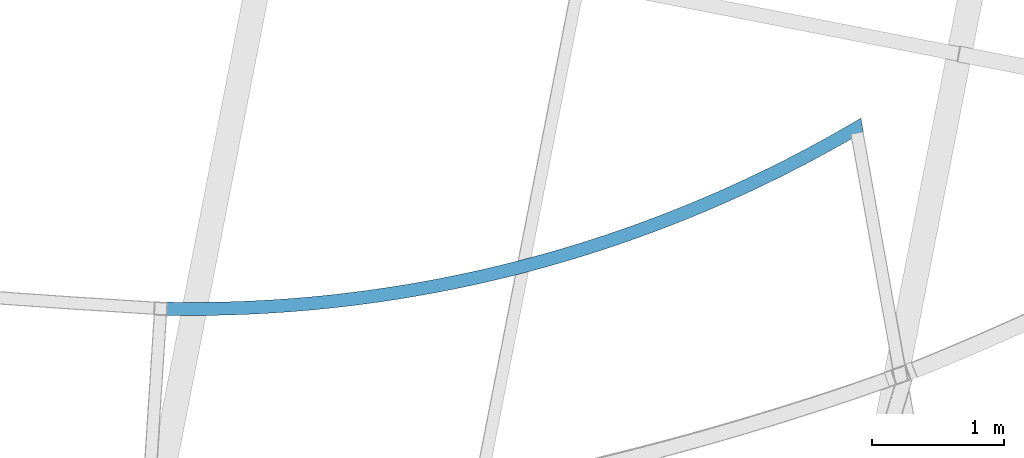
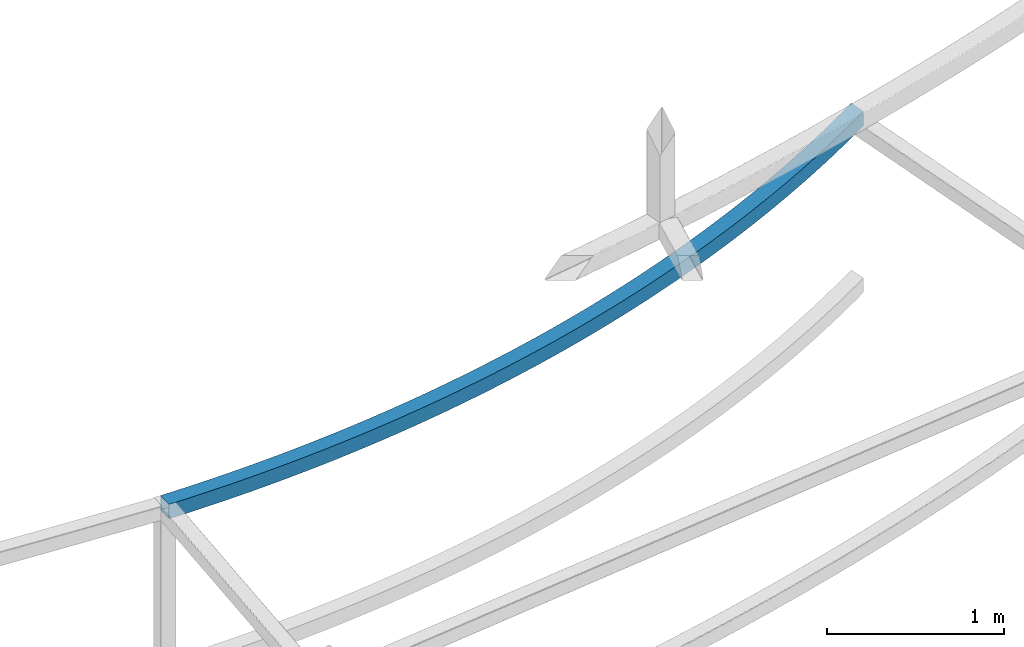
# One storey, part 210 of 215: 1 beam, 1 element without a shape of its own.
"""IFC2X3 building model written with IfcOpenShell, lengths in millimetres."""

from ifc_helpers import new_model, si_unit, frame, origin_with_axes, place, context, subcontext, project, spatial, faceted_brep, material, type_object, element, aggregate, save


model = new_model("IFC2X3")

# Units and contexts
model_context = context("Model", 3, precision=1e-05, world=origin_with_axes())
body_context = subcontext(model_context, "Body", "Model", "MODEL_VIEW")
ifc_project = project(units=[si_unit("LENGTHUNIT", "METRE", prefix="MILLI"), si_unit("AREAUNIT", "SQUARE_METRE"), si_unit("VOLUMEUNIT", "CUBIC_METRE"), si_unit("MASSUNIT", "GRAM", prefix="KILO"), si_unit("TIMEUNIT", "SECOND"), si_unit("PLANEANGLEUNIT", "RADIAN"), si_unit("SOLIDANGLEUNIT", "STERADIAN"), si_unit("THERMODYNAMICTEMPERATUREUNIT", "DEGREE_CELSIUS"), si_unit("LUMINOUSINTENSITYUNIT", "LUMEN")], contexts=[model_context])

# Site, building, storey
site_placement = place(None, origin_with_axes())
site = spatial("IfcSite", under=ifc_project, at=site_placement, CompositionType="ELEMENT")
building_placement = place(site_placement, origin_with_axes())
building = spatial("IfcBuilding", under=site, at=building_placement, Name="Undefined", CompositionType="ELEMENT")
storey_placement = place(building_placement, origin_with_axes())
storey = spatial("IfcBuildingStorey", under=building, at=storey_placement, Name="Undefined", CompositionType="ELEMENT", Elevation=0.0)

# Assembly, beam
assembly_placement = place(storey_placement, origin_with_axes())
assembly = element("IfcElementAssembly", 1, at=assembly_placement, inside=storey, Name="Steel Assembly", AssemblyPlace="NOTDEFINED", PredefinedType="RIGID_FRAME")
ifc_material = material(Name="STEEL/S275JR")
beam_type = type_object("IfcBeamType", PredefinedType="NOTDEFINED")
beam_placement = place(assembly_placement, frame((79292.5596210505, 5933.80750631125, 6760.00000147687), z_axis=(-0.254036429912331, 0.967194650666244, 0.0), x_axis=(0.967194650666242, 0.254036429912337, 0.0)))
beam = element("IfcBeam", 2, at=beam_placement, type_object=beam_type, material=ifc_material, Name="POUTRE", context=body_context, shape_type="Brep", body=[
    faceted_brep([(13.8027650535223, 50.0, 48.0570876861802), (13.8027650535223, -50.0, 48.0570876861802), (120.962516663611, -50.0, 17.926930383619), (120.962516663611, 50.0, 17.926930383619), (228.452636376329, -50.0, -11.0025166964588), (228.452636376329, 50.0, -11.0025166964588), (336.259670852232, -50.0, -38.7276327778127), (336.259670852232, 50.0, -38.7276327778127), (444.370127087197, -50.0, -65.2449478168783), (444.370127087197, 50.0, -65.2449478168783), (552.770474101198, -50.0, -90.5511429370781), (552.770474101198, 50.0, -90.5511429370781), (661.447144631748, -50.0, -114.643050844223), (661.447144631748, 50.0, -114.643050844223), (770.386536832113, -50.0, -137.517656222892), (770.386536832113, 50.0, -137.517656222892), (879.575015973576, -50.0, -159.172096113844), (879.575015973576, 50.0, -159.172096113844), (988.998916151962, -50.0, -179.603660272365), (988.998916151962, 50.0, -179.603660272365), (1098.64454199812, -50.0, -198.809791507432), (1098.64454199812, 50.0, -198.809791507432), (1208.49817039195, -50.0, -216.788086001812), (1208.49817039195, 50.0, -216.788086001812), (1318.54605217997, -50.0, -233.536293612895), (1318.54605217997, 50.0, -233.536293612895), (1428.77441389619, -50.0, -249.052318154325), (1428.77441389619, 50.0, -249.052318154325), (1539.16945948597, -50.0, -263.334217658366), (1539.16945948597, 50.0, -263.334217658366), (1649.71737203271, -50.0, -276.380204618938), (1649.71737203271, 50.0, -276.380204618938), (1760.40431548712, -50.0, -288.188646215367), (1760.40431548712, 50.0, -288.188646215367), (1871.21643639897, -50.0, -298.758064516705), (1871.21643639897, 50.0, -298.758064516705), (1982.13986565101, -50.0, -308.087136666752), (1982.13986565101, 50.0, -308.087136666752), (2093.16072019475, -50.0, -316.174695049598), (2093.16072019475, 50.0, -316.174695049598), (2204.26510478801, -50.0, -323.019727435752), (2204.26510478801, 50.0, -323.019727435752), (2315.43911373413, -50.0, -328.621377108855), (2315.43911373413, 50.0, -328.621377108855), (2426.66883262237, -50.0, -332.978942972903), (2426.66883262237, 50.0, -332.978942972903), (2537.94034006934, -50.0, -336.091879639967), (2537.94034006934, 50.0, -336.091879639967), (2649.23970946147, -50.0, -337.959797498483), (2649.23970946147, 50.0, -337.959797498483), (2760.55301069804, -50.0, -338.582462762013), (2760.55301069804, 50.0, -338.582462762013), (2871.86631193462, -50.0, -337.959797498483), (2871.86631193462, 50.0, -337.959797498483), (2983.16568132676, -50.0, -336.091879639966), (2983.16568132676, 50.0, -336.091879639966), (3094.43718877374, -50.0, -332.978942972903), (3094.43718877374, 50.0, -332.978942972903), (3205.66690766196, -50.0, -328.621377108859), (3205.66690766196, 50.0, -328.621377108859), (3316.8409166081, -50.0, -323.019727435752), (3316.8409166081, 50.0, -323.019727435752), (3427.94530120135, -50.0, -316.174695049598), (3427.94530120135, 50.0, -316.174695049598), (3538.96615574509, -50.0, -308.087136666756), (3538.96615574509, 50.0, -308.087136666756), (3649.88958499713, -50.0, -298.758064516707), (3649.88958499713, 50.0, -298.758064516707), (3760.70170590898, -50.0, -288.188646215367), (3760.70170590898, 50.0, -288.188646215367), (3871.38864936339, -50.0, -276.380204618943), (3871.38864936339, 50.0, -276.380204618943), (3981.93656191012, -50.0, -263.334217658368), (3981.93656191012, 50.0, -263.334217658368), (4092.3316074999, -50.0, -249.052318154323), (4092.3316074999, 50.0, -249.052318154323), (4202.55996921612, -50.0, -233.536293612891), (4202.55996921612, 50.0, -233.536293612891), (4312.60785100416, -50.0, -216.788086001814), (4312.60785100416, 50.0, -216.788086001814), (4422.46147939797, -50.0, -198.809791507434), (4422.46147939797, 50.0, -198.809791507434), (4532.10710524413, -50.0, -179.603660272365), (4532.10710524413, 50.0, -179.603660272365), (4641.53100542253, -50.0, -159.172096113847), (4641.53100542253, 50.0, -159.172096113847), (4750.71948456398, -50.0, -137.517656222888), (4750.71948456398, 50.0, -137.517656222888), (4859.65887676434, -50.0, -114.643050844228), (4859.65887676434, 50.0, -114.643050844228), (4968.3355472949, -50.0, -90.5511429370872), (4968.3355472949, 50.0, -90.5511429370872), (5076.73589430888, -50.0, -65.2449478168783), (5076.73589430888, 50.0, -65.2449478168783), (5184.84635054386, -50.0, -38.7276327778127), (5184.84635054386, 50.0, -38.7276327778127), (5292.65338501976, -50.0, -11.0025166964642), (5292.65338501976, 50.0, -11.0025166964642), (5400.14350473249, 50.0, 17.9269303836136), (5400.14350473249, -50.0, 17.9269303836136), (5507.30325634258, -50.0, 48.0570876861784), (5507.30325634258, 50.0, 48.0570876861784), (5318.10162998782, -50.0, -107.710255931986), (5426.67205241122, -50.0, -78.4900606400479), (5209.21110772823, -50.0, -135.714016396061), (5100.01411424468, -50.0, -162.497837113911), (4990.52431650693, -50.0, -188.05836585342), (4880.75541813184, -50.0, -212.392403488268), (4770.72115766814, -50.0, -235.496904398377), (4660.43530687704, -50.0, -257.368976851052), (4549.91166900842, -50.0, -278.005883362919), (4439.16407707335, -50.0, -297.405041042563), (4328.20639211274, -50.0, -315.564021913768), (4217.05250146255, -50.0, -332.480553219433), (4105.7163170155, -50.0, -348.152517706007), (3994.21177348007, -50.0, -362.577953888478), (3882.55282663641, -50.0, -375.755056295897), (3770.75345158949, -50.0, -387.682175697311), (3658.82764102024, -50.0, -398.35781930821), (3546.78940343398, -50.0, -407.780650977355), (3434.65276140743, -50.0, -415.949491353997), (3322.43174983331, -50.0, -422.863318035485), (3210.14041416411, -50.0, -428.521265695259), (3097.79280865387, -50.0, -432.922626191103), (2985.4029945994, -50.0, -436.066848653812), (2872.98503858023, -50.0, -437.95353955614), (2760.55301069804, -50.0, -438.582462762013), (2648.12098281589, -50.0, -437.95353955614), (2535.70302679668, -50.0, -436.066848653814), (2423.3132127422, -50.0, -432.922626191103), (2310.96560723199, -50.0, -428.521265695261), (2198.67427156278, -50.0, -422.863318035488), (2086.45325998867, -50.0, -415.949491353995), (1974.3166179621, -50.0, -407.780650977355), (1862.27838037588, -50.0, -398.35781930821), (1750.35256980661, -50.0, -387.682175697308), (1638.55319475969, -50.0, -375.755056295897), (1526.89424791602, -50.0, -362.577953888482), (1415.38970438059, -50.0, -348.152517706007), (1304.05351993356, -50.0, -332.480553219437), (1192.89962928335, -50.0, -315.564021913769), (1081.94194432274, -50.0, -297.405041042559), (971.194352387669, -50.0, -278.005883362923), (860.670714519059, -50.0, -257.368976851052), (750.38486372793, -50.0, -235.496904398373), (640.350603264247, -50.0, -212.392403488269), (530.581704889162, -50.0, -188.058365853412), (421.091907151422, -50.0, -162.497837113911), (311.894913667871, -50.0, -135.714016396065), (203.004391408278, -50.0, -107.710255931985), (94.4339689848566, -50.0, -78.4900606400461), (-13.8027650534787, -50.0, -48.0570876862002), (-13.8027650534787, 50.0, -48.0570876862002), (94.4339689848566, 50.0, -78.4900606400461), (203.004391408278, 50.0, -107.710255931985), (311.894913667871, 50.0, -135.714016396065), (421.091907151422, 50.0, -162.497837113911), (530.581704889162, 50.0, -188.058365853412), (640.350603264247, 50.0, -212.392403488269), (750.38486372793, 50.0, -235.496904398373), (860.670714519059, 50.0, -257.368976851052), (971.194352387669, 50.0, -278.005883362923), (1081.94194432274, 50.0, -297.405041042559), (1192.89962928335, 50.0, -315.564021913769), (1304.05351993356, 50.0, -332.480553219437), (1415.38970438059, 50.0, -348.152517706007), (1526.89424791602, 50.0, -362.577953888482), (1638.55319475969, 50.0, -375.755056295897), (1750.35256980661, 50.0, -387.682175697308), (1862.27838037588, 50.0, -398.35781930821), (1974.3166179621, 50.0, -407.780650977355), (2086.45325998867, 50.0, -415.949491353995), (2198.67427156278, 50.0, -422.863318035488), (2310.96560723199, 50.0, -428.521265695261), (2423.3132127422, 50.0, -432.922626191103), (2535.70302679668, 50.0, -436.066848653814), (2648.12098281589, 50.0, -437.95353955614), (2760.55301069804, 50.0, -438.582462762013), (2872.98503858023, 50.0, -437.95353955614), (2985.4029945994, 50.0, -436.066848653812), (3097.79280865387, 50.0, -432.922626191103), (3210.14041416411, 50.0, -428.521265695259), (3322.43174983331, 50.0, -422.863318035485), (3434.65276140743, 50.0, -415.949491353997), (3546.78940343398, 50.0, -407.780650977355), (3658.82764102024, 50.0, -398.35781930821), (3770.75345158949, 50.0, -387.682175697311), (3882.55282663641, 50.0, -375.755056295897), (3994.21177348007, 50.0, -362.577953888478), (4105.7163170155, 50.0, -348.152517706007), (4217.05250146255, 50.0, -332.480553219433), (4328.20639211274, 50.0, -315.564021913768), (4439.16407707335, 50.0, -297.405041042563), (4549.91166900842, 50.0, -278.005883362919), (4660.43530687704, 50.0, -257.368976851052), (4770.72115766814, 50.0, -235.496904398377), (4880.75541813184, 50.0, -212.392403488268), (4990.52431650693, 50.0, -188.05836585342), (5100.01411424468, 50.0, -162.497837113911), (5209.21110772823, 50.0, -135.714016396061), (5318.10162998782, 50.0, -107.710255931986), (5426.67205241122, 50.0, -78.4900606400479), (5501.22198712551, 50.0, -57.5288207520553), (5501.22198712551, -50.0, -57.5288207520553), (5509.12924965772, -50.0, 41.6995266815829), (5509.6916876808, -50.0, 48.7575692516257), (5509.6916876808, 50.0, 48.7575692516257), (5509.12924965772, 50.0, 41.6995266815829), (12.6985438492411, 46.0, 44.2125206712844), (12.6985438492411, -46.0, 44.2125206712844), (-12.6985438491974, -46.0, -44.2125206713063), (-12.6985438491974, 46.0, -44.2125206713063), (95.4951108920213, 46.0, -74.6333809990974), (119.90137475646, 46.0, 14.0702507426704), (119.90137475646, -46.0, 14.0702507426704), (95.4951108920213, -46.0, -74.6333809990974), (204.022321206998, -46.0, -103.841946362561), (204.022321206998, 46.0, -103.841946362561), (227.434706577609, 46.0, -14.870826265882), (227.434706577609, -46.0, -14.870826265882), (335.285080564863, -46.0, -42.6070881225442), (312.869503955226, -46.0, -131.834561051332), (312.869503955226, 46.0, -131.834561051332), (335.285080564863, 46.0, -42.6070881225442), (443.438998289785, 46.0, -69.1350633887596), (443.438998289785, -46.0, -69.1350633887596), (422.023035948863, -46.0, -158.607721542032), (422.023035948863, 46.0, -158.607721542032), (531.469255657648, 46.0, -184.158076936761), (551.882923332712, 46.0, -94.4514318537331), (551.882923332712, -46.0, -94.4514318537331), (531.469255657648, -46.0, -184.158076936761), (641.194464918954, -46.0, -208.482429382504), (641.194464918954, 46.0, -208.482429382504), (660.603282977056, 46.0, -118.553024949984), (660.603282977056, -46.0, -118.553024949984), (769.586469907954, -46.0, -141.436826149909), (751.184930652118, -46.0, -231.577734471355), (751.184930652118, 46.0, -231.577734471355), (769.586469907954, 46.0, -141.436826149909), (878.818843915389, 46.0, -163.099971343334), (878.818843915389, -46.0, -163.099971343334), (861.426886577246, -46.0, -253.44110162156), (861.426886577246, 46.0, -253.44110162156), (971.906534938258, 46.0, -274.0697944393), (988.286733601388, 46.0, -183.539749195985), (988.286733601388, -46.0, -183.539749195985), (971.906534938258, -46.0, -274.0697944393), (1082.61004822975, -46.0, -293.461231061156), (1082.61004822975, 46.0, -293.461231061156), (1097.97643809109, 46.0, -202.753601488836), (1097.97643809109, -46.0, -202.753601488836), (1207.87422874761, -46.0, -220.739123438289), (1193.52357092767, -46.0, -311.612984477291), (1193.52357092767, 46.0, -311.612984477291), (1207.87422874761, 46.0, -220.739123438289), (1317.9663508901, 46.0, -237.494063997157), (1317.9663508901, -46.0, -237.494063997157), (1304.63322122343, -46.0, -328.522782835174), (1304.63322122343, 46.0, -328.522782835174), (1415.92509276122, 46.0, -344.188509723939), (1428.23902551559, 46.0, -253.016326136392), (1428.23902551559, -46.0, -253.016326136392), (1415.92509276122, -46.0, -344.188509723939), (1527.38525637881, -46.0, -358.608204439275), (1527.38525637881, 46.0, -358.608204439275), (1538.67845102318, 46.0, -267.303967107575), (1538.67845102318, -46.0, -267.303967107575), (1649.27080494179, -46.0, -280.355198686018), (1638.99976185062, -46.0, -371.780062228816), (1638.99976185062, 46.0, -371.780062228816), (1649.27080494179, 46.0, -280.355198686018), (1760.0022456599, 46.0, -292.168387394646), (1760.0022456599, -46.0, -292.168387394646), (1750.75463963381, -46.0, -383.702434518033), (1750.75463963381, 46.0, -383.702434518033), (1862.63590261679, 46.0, -394.37382911655), (1870.85891415805, 46.0, -302.742054708368), (1870.85891415805, -46.0, -302.742054708368), (1862.63590261679, -46.0, -394.37382911655), (1974.62954786967, -46.0, -403.792910404931), (1974.62954786967, 46.0, -403.792910404931), (1981.82693574346, 46.0, -312.074877239176), (1981.82693574346, -46.0, -312.074877239176), (2092.8924217865, -46.0, -320.165686901773), (2086.72155839692, -46.0, -411.958499501819), (2086.72155839692, 46.0, -411.958499501819), (2092.8924217865, 46.0, -320.165686901773), (2204.04147145899, 46.0, -327.013471059741), (2204.04147145899, -46.0, -327.013471059741), (2198.8979048918, -46.0, -418.869574411499), (2198.8979048918, 46.0, -418.869574411499), (2311.14454749208, 46.0, -424.525270151802), (2315.26017347405, 46.0, -332.617372652316), (2315.26017347405, -46.0, -332.617372652316), (2311.14454749208, -46.0, -424.525270151802), (2423.44743753743, -46.0, -428.924878862377), (2423.44743753743, 46.0, -428.924878862377), (2426.53460782717, 46.0, -336.976690301633), (2426.53460782717, -46.0, -336.976690301633), (2537.85084753842, -46.0, -340.090878400519), (2535.7925193276, -46.0, -432.067849893265), (2535.7925193276, 46.0, -432.067849893265), (2537.85084753842, 46.0, -340.090878400519), (2649.19496039565, 46.0, -341.959547180792), (2649.19496039565, -46.0, -341.959547180792), (2648.1657318817, -46.0, -433.953789873831), (2648.1657318817, 46.0, -433.953789873831), (2760.55301069804, 46.0, -434.582462762011), (2760.55301069804, 46.0, -342.582462762013), (2760.55301069804, -46.0, -342.582462762013), (2760.55301069804, -46.0, -434.582462762011), (2872.9402895144, -46.0, -433.953789873834), (2872.9402895144, 46.0, -433.953789873834), (2871.91106100044, 46.0, -341.959547180792), (2871.91106100044, -46.0, -341.959547180792), (2983.25517385767, -46.0, -340.090878400521), (2985.3135020685, -46.0, -432.067849893261), (2985.3135020685, 46.0, -432.067849893261), (2983.25517385767, 46.0, -340.090878400521), (3094.57141356895, 46.0, -336.976690301632), (3094.57141356895, -46.0, -336.976690301632), (3097.65858385868, -46.0, -428.924878862374), (3097.65858385868, 46.0, -428.924878862374), (3209.96147390403, 46.0, -424.525270151804), (3205.84584792206, 46.0, -332.617372652316), (3205.84584792206, -46.0, -332.617372652316), (3209.96147390403, -46.0, -424.525270151804), (3322.20811650431, -46.0, -418.869574411499), (3322.20811650431, 46.0, -418.869574411499), (3317.06454993712, 46.0, -327.013471059741), (3317.06454993712, -46.0, -327.013471059741), (3428.21359960959, -46.0, -320.165686901772), (3434.38446299918, -46.0, -411.958499501818), (3434.38446299918, 46.0, -411.958499501818), (3428.21359960959, 46.0, -320.165686901772), (3539.27908565263, 46.0, -312.074877239178), (3539.27908565263, -46.0, -312.074877239178), (3546.47647352643, -46.0, -403.792910404929), (3546.47647352643, 46.0, -403.792910404929), (3658.47011877931, 46.0, -394.373829116554), (3650.24710723804, 46.0, -302.742054708368), (3650.24710723804, -46.0, -302.742054708368), (3658.47011877931, -46.0, -394.373829116554), (3770.35138176229, -46.0, -383.702434518034), (3770.35138176229, 46.0, -383.702434518034), (3761.10377573621, 46.0, -292.168387394644), (3761.10377573621, -46.0, -292.168387394644), (3871.8352164543, -46.0, -280.355198686018), (3882.10625954547, -46.0, -371.780062228818), (3882.10625954547, 46.0, -371.780062228818), (3871.8352164543, 46.0, -280.355198686018), (3982.42757037292, 46.0, -267.303967107571), (3982.42757037292, -46.0, -267.303967107571), (3993.72076501729, -46.0, -358.608204439279), (3993.72076501729, 46.0, -358.608204439279), (4105.18092863486, 46.0, -344.188509723937), (4092.86699588053, 46.0, -253.016326136394), (4092.86699588053, -46.0, -253.016326136394), (4105.18092863486, -46.0, -344.188509723937), (4216.47280017269, -46.0, -328.522782835178), (4216.47280017269, 46.0, -328.522782835178), (4203.13967050599, 46.0, -237.494063997154), (4203.13967050599, -46.0, -237.494063997154), (4313.23179264851, -46.0, -220.739123438296), (4327.58245046841, -46.0, -311.612984477295), (4327.58245046841, 46.0, -311.612984477295), (4313.23179264851, 46.0, -220.739123438296), (4423.129583305, 46.0, -202.753601488839), (4423.129583305, -46.0, -202.753601488839), (4438.49597316634, -46.0, -293.461231061156), (4438.49597316634, 46.0, -293.461231061156), (4549.19948645784, 46.0, -274.0697944393), (4532.81928779471, 46.0, -183.539749195988), (4532.81928779471, -46.0, -183.539749195988), (4549.19948645784, -46.0, -274.0697944393), (4659.67913481886, -46.0, -253.44110162156), (4659.67913481886, 46.0, -253.44110162156), (4642.2871774807, 46.0, -163.099971343334), (4642.2871774807, -46.0, -163.099971343334), (4751.51955148813, -46.0, -141.436826149911), (4769.921090744, -46.0, -231.577734471359), (4769.921090744, 46.0, -231.577734471359), (4751.51955148813, 46.0, -141.436826149911), (4860.50273841903, 46.0, -118.553024949988), (4860.50273841903, -46.0, -118.553024949988), (4879.91155647715, -46.0, -208.482429382508), (4879.91155647715, 46.0, -208.482429382508), (4989.63676573845, 46.0, -184.158076936761), (4969.22309806338, 46.0, -94.4514318537367), (4969.22309806338, -46.0, -94.4514318537367), (4989.63676573845, -46.0, -184.158076936761), (5099.08298544724, -46.0, -158.60772154203), (5099.08298544724, 46.0, -158.60772154203), (5077.6670231063, 46.0, -69.1350633887596), (5077.6670231063, -46.0, -69.1350633887596), (5185.82094083124, -46.0, -42.607088122546), (5208.23651744086, -46.0, -131.834561051332), (5208.23651744086, 46.0, -131.834561051332), (5185.82094083124, 46.0, -42.607088122546), (5293.67131481848, 46.0, -14.8708262658838), (5293.67131481848, -46.0, -14.8708262658838), (5317.08370018911, -46.0, -103.841946362561), (5317.08370018911, 46.0, -103.841946362561), (5425.61091050407, 46.0, -74.6333809991011), (5401.20464663963, 46.0, 14.0702507426668), (5401.20464663963, -46.0, 14.0702507426668), (5508.40747754686, 46.0, 44.2125206712863), (5508.40747754686, -46.0, 44.2125206712863), (5425.61091050407, -46.0, -74.6333809991011), (5501.56068083542, -46.0, -53.2785486782577), (5501.56068083542, 46.0, -53.2785486782577), (5509.12924965771, 46.0, 41.6995266815848), (5509.35156814911, 46.0, 44.4894045207056), (5509.35156814911, -46.0, 44.4894045207056), (5509.12924965771, -46.0, 41.6995266815848)], [[[0, 1, 2, 3]], [[3, 2, 4, 5]], [[5, 4, 6, 7]], [[7, 6, 8, 9]], [[9, 8, 10, 11]], [[11, 10, 12, 13]], [[13, 12, 14, 15]], [[15, 14, 16, 17]], [[17, 16, 18, 19]], [[19, 18, 20, 21]], [[21, 20, 22, 23]], [[23, 22, 24, 25]], [[25, 24, 26, 27]], [[27, 26, 28, 29]], [[29, 28, 30, 31]], [[31, 30, 32, 33]], [[33, 32, 34, 35]], [[35, 34, 36, 37]], [[37, 36, 38, 39]], [[39, 38, 40, 41]], [[41, 40, 42, 43]], [[43, 42, 44, 45]], [[45, 44, 46, 47]], [[47, 46, 48, 49]], [[49, 48, 50, 51]], [[51, 50, 52, 53]], [[53, 52, 54, 55]], [[55, 54, 56, 57]], [[57, 56, 58, 59]], [[59, 58, 60, 61]], [[61, 60, 62, 63]], [[63, 62, 64, 65]], [[65, 64, 66, 67]], [[67, 66, 68, 69]], [[69, 68, 70, 71]], [[71, 70, 72, 73]], [[73, 72, 74, 75]], [[75, 74, 76, 77]], [[77, 76, 78, 79]], [[79, 78, 80, 81]], [[81, 80, 82, 83]], [[83, 82, 84, 85]], [[85, 84, 86, 87]], [[87, 86, 88, 89]], [[89, 88, 90, 91]], [[91, 90, 92, 93]], [[93, 92, 94, 95]], [[95, 94, 96, 97]], [[98, 99, 100, 101]], [[97, 96, 99, 98]], [[96, 102, 103, 99]], [[94, 104, 102, 96]], [[92, 105, 104, 94]], [[90, 106, 105, 92]], [[88, 107, 106, 90]], [[86, 108, 107, 88]], [[84, 109, 108, 86]], [[82, 110, 109, 84]], [[80, 111, 110, 82]], [[78, 112, 111, 80]], [[76, 113, 112, 78]], [[74, 114, 113, 76]], [[72, 115, 114, 74]], [[70, 116, 115, 72]], [[68, 117, 116, 70]], [[66, 118, 117, 68]], [[64, 119, 118, 66]], [[62, 120, 119, 64]], [[60, 121, 120, 62]], [[58, 122, 121, 60]], [[56, 123, 122, 58]], [[54, 124, 123, 56]], [[52, 125, 124, 54]], [[50, 126, 125, 52]], [[48, 127, 126, 50]], [[46, 128, 127, 48]], [[44, 129, 128, 46]], [[42, 130, 129, 44]], [[40, 131, 130, 42]], [[38, 132, 131, 40]], [[36, 133, 132, 38]], [[34, 134, 133, 36]], [[32, 135, 134, 34]], [[30, 136, 135, 32]], [[28, 137, 136, 30]], [[26, 138, 137, 28]], [[24, 139, 138, 26]], [[22, 140, 139, 24]], [[20, 141, 140, 22]], [[18, 142, 141, 20]], [[16, 143, 142, 18]], [[14, 144, 143, 16]], [[12, 145, 144, 14]], [[10, 146, 145, 12]], [[8, 147, 146, 10]], [[6, 148, 147, 8]], [[4, 149, 148, 6]], [[2, 150, 149, 4]], [[1, 151, 150, 2]], [[151, 152, 153, 150]], [[150, 153, 154, 149]], [[149, 154, 155, 148]], [[148, 155, 156, 147]], [[147, 156, 157, 146]], [[146, 157, 158, 145]], [[145, 158, 159, 144]], [[144, 159, 160, 143]], [[143, 160, 161, 142]], [[142, 161, 162, 141]], [[141, 162, 163, 140]], [[140, 163, 164, 139]], [[139, 164, 165, 138]], [[138, 165, 166, 137]], [[137, 166, 167, 136]], [[136, 167, 168, 135]], [[135, 168, 169, 134]], [[134, 169, 170, 133]], [[133, 170, 171, 132]], [[132, 171, 172, 131]], [[131, 172, 173, 130]], [[130, 173, 174, 129]], [[129, 174, 175, 128]], [[128, 175, 176, 127]], [[127, 176, 177, 126]], [[126, 177, 178, 125]], [[125, 178, 179, 124]], [[124, 179, 180, 123]], [[123, 180, 181, 122]], [[122, 181, 182, 121]], [[121, 182, 183, 120]], [[120, 183, 184, 119]], [[119, 184, 185, 118]], [[118, 185, 186, 117]], [[117, 186, 187, 116]], [[116, 187, 188, 115]], [[115, 188, 189, 114]], [[114, 189, 190, 113]], [[113, 190, 191, 112]], [[112, 191, 192, 111]], [[111, 192, 193, 110]], [[110, 193, 194, 109]], [[109, 194, 195, 108]], [[108, 195, 196, 107]], [[107, 196, 197, 106]], [[106, 197, 198, 105]], [[105, 198, 199, 104]], [[104, 199, 200, 102]], [[102, 200, 201, 103]], [[103, 201, 202, 203]], [[100, 99, 103, 203, 204]], [[100, 204, 205]], [[101, 100, 205, 206]], [[101, 206, 207]], [[201, 98, 101, 207, 202]], [[200, 97, 98, 201]], [[199, 95, 97, 200]], [[198, 93, 95, 199]], [[197, 91, 93, 198]], [[196, 89, 91, 197]], [[195, 87, 89, 196]], [[194, 85, 87, 195]], [[193, 83, 85, 194]], [[192, 81, 83, 193]], [[191, 79, 81, 192]], [[190, 77, 79, 191]], [[189, 75, 77, 190]], [[188, 73, 75, 189]], [[187, 71, 73, 188]], [[186, 69, 71, 187]], [[185, 67, 69, 186]], [[184, 65, 67, 185]], [[183, 63, 65, 184]], [[182, 61, 63, 183]], [[181, 59, 61, 182]], [[180, 57, 59, 181]], [[179, 55, 57, 180]], [[178, 53, 55, 179]], [[177, 51, 53, 178]], [[176, 49, 51, 177]], [[175, 47, 49, 176]], [[174, 45, 47, 175]], [[173, 43, 45, 174]], [[172, 41, 43, 173]], [[171, 39, 41, 172]], [[170, 37, 39, 171]], [[169, 35, 37, 170]], [[168, 33, 35, 169]], [[167, 31, 33, 168]], [[166, 29, 31, 167]], [[165, 27, 29, 166]], [[164, 25, 27, 165]], [[163, 23, 25, 164]], [[162, 21, 23, 163]], [[161, 19, 21, 162]], [[160, 17, 19, 161]], [[159, 15, 17, 160]], [[158, 13, 15, 159]], [[157, 11, 13, 158]], [[156, 9, 11, 157]], [[155, 7, 9, 156]], [[154, 5, 7, 155]], [[153, 3, 5, 154]], [[152, 0, 3, 153]], [[151, 1, 0, 152], [208, 209, 210, 211]], [[208, 211, 212, 213]], [[209, 208, 213, 214]], [[210, 209, 214, 215]], [[211, 210, 215, 212]], [[212, 215, 216, 217]], [[213, 212, 217, 218]], [[214, 213, 218, 219]], [[215, 214, 219, 216]], [[216, 219, 220, 221]], [[217, 216, 221, 222]], [[218, 217, 222, 223]], [[219, 218, 223, 220]], [[220, 223, 224, 225]], [[221, 220, 225, 226]], [[222, 221, 226, 227]], [[223, 222, 227, 224]], [[224, 227, 228, 229]], [[225, 224, 229, 230]], [[226, 225, 230, 231]], [[227, 226, 231, 228]], [[228, 231, 232, 233]], [[229, 228, 233, 234]], [[230, 229, 234, 235]], [[231, 230, 235, 232]], [[232, 235, 236, 237]], [[233, 232, 237, 238]], [[234, 233, 238, 239]], [[235, 234, 239, 236]], [[236, 239, 240, 241]], [[237, 236, 241, 242]], [[238, 237, 242, 243]], [[239, 238, 243, 240]], [[240, 243, 244, 245]], [[241, 240, 245, 246]], [[242, 241, 246, 247]], [[243, 242, 247, 244]], [[244, 247, 248, 249]], [[245, 244, 249, 250]], [[246, 245, 250, 251]], [[247, 246, 251, 248]], [[248, 251, 252, 253]], [[249, 248, 253, 254]], [[250, 249, 254, 255]], [[251, 250, 255, 252]], [[252, 255, 256, 257]], [[253, 252, 257, 258]], [[254, 253, 258, 259]], [[255, 254, 259, 256]], [[256, 259, 260, 261]], [[257, 256, 261, 262]], [[258, 257, 262, 263]], [[259, 258, 263, 260]], [[260, 263, 264, 265]], [[261, 260, 265, 266]], [[262, 261, 266, 267]], [[263, 262, 267, 264]], [[264, 267, 268, 269]], [[265, 264, 269, 270]], [[266, 265, 270, 271]], [[267, 266, 271, 268]], [[268, 271, 272, 273]], [[269, 268, 273, 274]], [[270, 269, 274, 275]], [[271, 270, 275, 272]], [[272, 275, 276, 277]], [[273, 272, 277, 278]], [[274, 273, 278, 279]], [[275, 274, 279, 276]], [[276, 279, 280, 281]], [[277, 276, 281, 282]], [[278, 277, 282, 283]], [[279, 278, 283, 280]], [[280, 283, 284, 285]], [[281, 280, 285, 286]], [[282, 281, 286, 287]], [[283, 282, 287, 284]], [[284, 287, 288, 289]], [[285, 284, 289, 290]], [[286, 285, 290, 291]], [[287, 286, 291, 288]], [[288, 291, 292, 293]], [[289, 288, 293, 294]], [[290, 289, 294, 295]], [[291, 290, 295, 292]], [[292, 295, 296, 297]], [[293, 292, 297, 298]], [[294, 293, 298, 299]], [[295, 294, 299, 296]], [[296, 299, 300, 301]], [[297, 296, 301, 302]], [[298, 297, 302, 303]], [[299, 298, 303, 300]], [[300, 303, 304, 305]], [[301, 300, 305, 306]], [[302, 301, 306, 307]], [[303, 302, 307, 304]], [[304, 307, 308, 309]], [[305, 304, 309, 310]], [[306, 305, 310, 311]], [[307, 306, 311, 308]], [[308, 311, 312, 313]], [[309, 308, 313, 314]], [[310, 309, 314, 315]], [[311, 310, 315, 312]], [[312, 315, 316, 317]], [[313, 312, 317, 318]], [[314, 313, 318, 319]], [[315, 314, 319, 316]], [[316, 319, 320, 321]], [[317, 316, 321, 322]], [[318, 317, 322, 323]], [[319, 318, 323, 320]], [[320, 323, 324, 325]], [[321, 320, 325, 326]], [[322, 321, 326, 327]], [[323, 322, 327, 324]], [[324, 327, 328, 329]], [[325, 324, 329, 330]], [[326, 325, 330, 331]], [[327, 326, 331, 328]], [[328, 331, 332, 333]], [[329, 328, 333, 334]], [[330, 329, 334, 335]], [[331, 330, 335, 332]], [[332, 335, 336, 337]], [[333, 332, 337, 338]], [[334, 333, 338, 339]], [[335, 334, 339, 336]], [[336, 339, 340, 341]], [[337, 336, 341, 342]], [[338, 337, 342, 343]], [[339, 338, 343, 340]], [[340, 343, 344, 345]], [[341, 340, 345, 346]], [[342, 341, 346, 347]], [[343, 342, 347, 344]], [[344, 347, 348, 349]], [[345, 344, 349, 350]], [[346, 345, 350, 351]], [[347, 346, 351, 348]], [[348, 351, 352, 353]], [[349, 348, 353, 354]], [[350, 349, 354, 355]], [[351, 350, 355, 352]], [[352, 355, 356, 357]], [[353, 352, 357, 358]], [[354, 353, 358, 359]], [[355, 354, 359, 356]], [[356, 359, 360, 361]], [[357, 356, 361, 362]], [[358, 357, 362, 363]], [[359, 358, 363, 360]], [[360, 363, 364, 365]], [[361, 360, 365, 366]], [[362, 361, 366, 367]], [[363, 362, 367, 364]], [[364, 367, 368, 369]], [[365, 364, 369, 370]], [[366, 365, 370, 371]], [[367, 366, 371, 368]], [[368, 371, 372, 373]], [[369, 368, 373, 374]], [[370, 369, 374, 375]], [[371, 370, 375, 372]], [[372, 375, 376, 377]], [[373, 372, 377, 378]], [[374, 373, 378, 379]], [[375, 374, 379, 376]], [[376, 379, 380, 381]], [[377, 376, 381, 382]], [[378, 377, 382, 383]], [[379, 378, 383, 380]], [[380, 383, 384, 385]], [[381, 380, 385, 386]], [[382, 381, 386, 387]], [[383, 382, 387, 384]], [[384, 387, 388, 389]], [[385, 384, 389, 390]], [[386, 385, 390, 391]], [[387, 386, 391, 388]], [[388, 391, 392, 393]], [[389, 388, 393, 394]], [[390, 389, 394, 395]], [[391, 390, 395, 392]], [[392, 395, 396, 397]], [[393, 392, 397, 398]], [[394, 393, 398, 399]], [[395, 394, 399, 396]], [[396, 399, 400, 401]], [[397, 396, 401, 402]], [[398, 397, 402, 403]], [[399, 398, 403, 400]], [[400, 403, 404, 405]], [[406, 405, 407, 408]], [[401, 400, 405, 406]], [[402, 401, 406, 409]], [[403, 402, 409, 404]], [[404, 409, 410, 411]], [[407, 405, 404, 411, 412]], [[407, 412, 413]], [[408, 407, 413, 414]], [[408, 414, 415]], [[409, 406, 408, 415, 410]], [[207, 206, 205, 204, 203, 202], [414, 413, 412, 411, 410, 415]]]),
])
aggregate(assembly, [beam])

save(model, "model.ifc")
